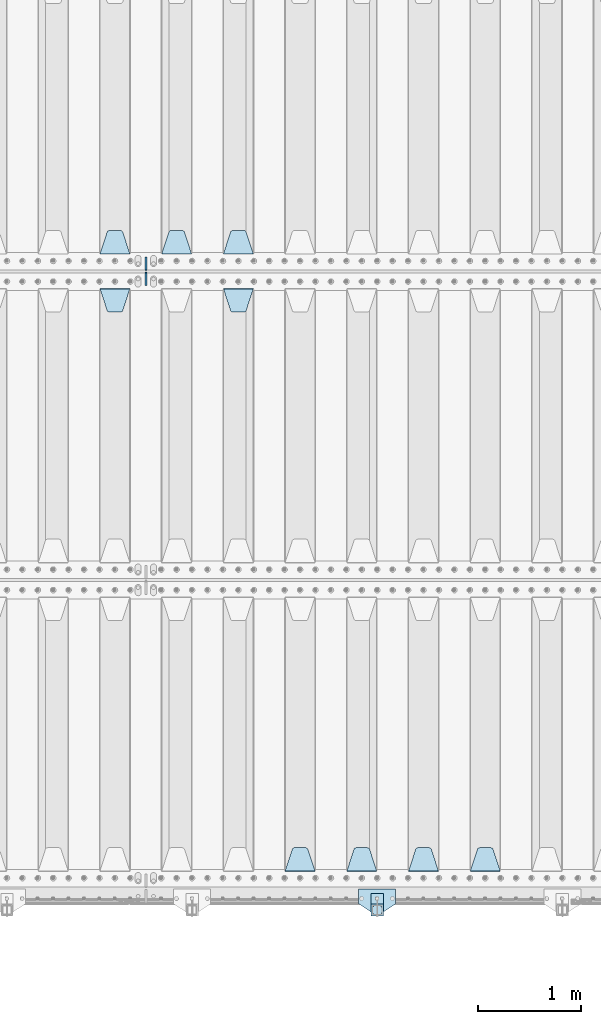
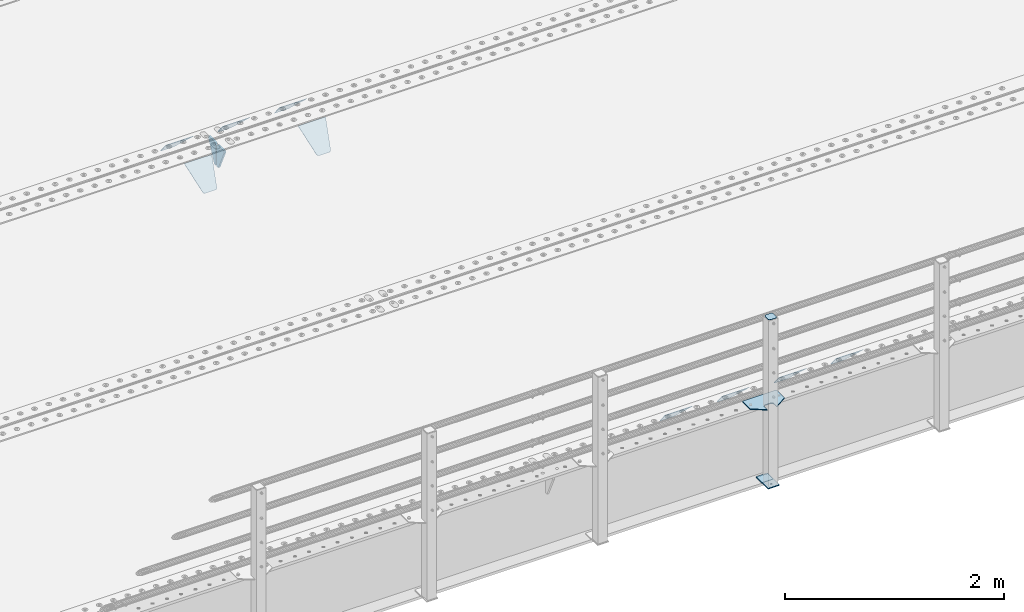
# One storey, part 208 of 257: 15 plates.
"""IFC2X3 building model written with IfcOpenShell, lengths in millimetres."""

from ifc_helpers import new_model, si_unit, frame, origin_with_axes, place, context, subcontext, project, spatial, faceted_brep, material, type_object, element, save


model = new_model("IFC2X3")

# Units and contexts
model_context = context("Model", 3, precision=1e-05, world=origin_with_axes())
body_context = subcontext(model_context, "Body", "Model", "MODEL_VIEW")
ifc_project = project(units=[si_unit("LENGTHUNIT", "METRE", prefix="MILLI"), si_unit("AREAUNIT", "SQUARE_METRE"), si_unit("VOLUMEUNIT", "CUBIC_METRE"), si_unit("MASSUNIT", "GRAM", prefix="KILO"), si_unit("TIMEUNIT", "SECOND"), si_unit("PLANEANGLEUNIT", "RADIAN"), si_unit("SOLIDANGLEUNIT", "STERADIAN"), si_unit("THERMODYNAMICTEMPERATUREUNIT", "DEGREE_CELSIUS"), si_unit("LUMINOUSINTENSITYUNIT", "LUMEN")], contexts=[model_context])

# Site, building, storey
site_placement = place(None, origin_with_axes())
site = spatial("IfcSite", under=ifc_project, at=site_placement, CompositionType="ELEMENT")
building_placement = place(site_placement, origin_with_axes())
building = spatial("IfcBuilding", under=site, at=building_placement, Name="Standard", CompositionType="ELEMENT")
storey_placement = place(building_placement, origin_with_axes())
storey = spatial("IfcBuildingStorey", under=building, at=storey_placement, Name="Undefined", CompositionType="ELEMENT", Elevation=0.0)

# Plates
ifc_material_1 = material(Name="STEEL/S355N")
plate_type_1 = type_object("IfcPlateType", PredefinedType="NOTDEFINED")
plate_1_placement = place(storey_placement, frame((51395.0, 168.232233047034, -1.76776695296758), z_axis=(0.0, 0.707106781186547, -0.707106781186548), x_axis=(-1.0, 0.0, 0.0)))
element("IfcPlate", 1, at=plate_1_placement, inside=storey, type_object=plate_type_1, material=ifc_material_1, context=body_context, shape_type="Brep", body=[
    faceted_brep([(0.0, -2.5, 0.0), (69.345504679477, -2.50000000000091, 300.17173142483), (69.345504679477, 2.5, 300.171731424831), (0.0, 2.5, 0.0), (70.927406119954, -2.50000000000091, 304.8974424154), (70.927406119954, 2.5, 304.8974424154), (73.3818627772271, -2.50000000000091, 309.234538108527), (73.3818627772271, 2.49999999999909, 309.234538108527), (76.6187032999587, -2.5, 313.023683126103), (76.6187032999587, 2.5, 313.023683126103), (80.5190132705029, -2.5, 316.125672595372), (80.5190132705029, 2.5, 316.125672595371), (84.9395038596849, -2.5, 318.426546230476), (84.9395038596849, 2.5, 318.426546230477), (89.7177759439219, -2.5, 319.841774983275), (89.7177759439219, 2.5, 319.841774983275), (94.6782862926484, -2.5, 320.319366455079), (94.6782862926484, 2.5, 320.319366455079), (195.321713707352, -2.5, 320.319366455079), (195.321713707352, 2.5, 320.319366455079), (200.282224056078, -2.5, 319.841774983275), (200.282224056078, 2.49999999999909, 319.841774983275), (205.060496140315, -2.5, 318.426546230476), (205.060496140315, 2.49999999999909, 318.426546230475), (209.480986729497, -2.5, 316.125672595371), (209.480986729497, 2.5, 316.125672595371), (213.381296700041, -2.50000000000091, 313.023683126102), (213.381296700041, 2.5, 313.023683126103), (216.618137222766, -2.50000000000091, 309.234538108527), (216.618137222766, 2.5, 309.234538108527), (219.072593880039, -2.5, 304.897442415399), (219.072593880039, 2.5, 304.897442415399), (220.654495320523, -2.50000000000091, 300.17173142483), (220.654495320523, 2.5, 300.171731424831), (290.0, -2.50000000000091, 0.0), (290.0, 2.5, 9.09494701772928e-13)], [[[0, 1, 2, 3]], [[1, 4, 5, 2]], [[4, 6, 7, 5]], [[6, 8, 9, 7]], [[8, 10, 11, 9]], [[10, 12, 13, 11]], [[12, 14, 15, 13]], [[14, 16, 17, 15]], [[16, 18, 19, 17]], [[18, 20, 21, 19]], [[20, 22, 23, 21]], [[22, 24, 25, 23]], [[24, 26, 27, 25]], [[26, 28, 29, 27]], [[28, 30, 31, 29]], [[30, 32, 33, 31]], [[32, 34, 35, 33]], [[34, 0, 3, 35]], [[5, 7, 9, 11, 13, 15, 17, 19, 21, 23, 25, 27, 29, 31, 33, 35, 3, 2]], [[34, 32, 30, 28, 26, 24, 22, 20, 18, 16, 14, 12, 10, 8, 6, 4, 1, 0]]]),
])
plate_2_placement = place(storey_placement, frame((50795.0, 168.232233047034, -1.76776695296758), z_axis=(0.0, 0.707106781186547, -0.707106781186548), x_axis=(-1.0, 0.0, 0.0)))
element("IfcPlate", 2, at=plate_2_placement, inside=storey, type_object=plate_type_1, material=ifc_material_1, context=body_context, shape_type="Brep", body=[
    faceted_brep([(0.0, -2.5, 0.0), (69.345504679477, -2.50000000000091, 300.17173142483), (69.345504679477, 2.5, 300.171731424831), (0.0, 2.5, 0.0), (70.927406119954, -2.50000000000091, 304.8974424154), (70.927406119954, 2.5, 304.8974424154), (73.3818627772271, -2.50000000000091, 309.234538108527), (73.3818627772271, 2.49999999999909, 309.234538108527), (76.6187032999587, -2.5, 313.023683126103), (76.6187032999587, 2.5, 313.023683126103), (80.5190132705029, -2.5, 316.125672595372), (80.5190132705029, 2.5, 316.125672595371), (84.9395038596849, -2.5, 318.426546230476), (84.9395038596849, 2.5, 318.426546230477), (89.7177759439219, -2.5, 319.841774983275), (89.7177759439219, 2.5, 319.841774983275), (94.6782862926484, -2.5, 320.319366455079), (94.6782862926484, 2.5, 320.319366455079), (195.321713707352, -2.5, 320.319366455079), (195.321713707352, 2.5, 320.319366455079), (200.282224056078, -2.5, 319.841774983275), (200.282224056078, 2.49999999999909, 319.841774983275), (205.060496140315, -2.5, 318.426546230476), (205.060496140315, 2.49999999999909, 318.426546230475), (209.480986729497, -2.5, 316.125672595371), (209.480986729497, 2.5, 316.125672595371), (213.381296700041, -2.50000000000091, 313.023683126102), (213.381296700041, 2.5, 313.023683126103), (216.618137222766, -2.50000000000091, 309.234538108527), (216.618137222766, 2.5, 309.234538108527), (219.072593880039, -2.5, 304.897442415399), (219.072593880039, 2.5, 304.897442415399), (220.654495320523, -2.50000000000091, 300.17173142483), (220.654495320523, 2.5, 300.171731424831), (290.0, -2.50000000000091, 0.0), (290.0, 2.5, 9.09494701772928e-13)], [[[0, 1, 2, 3]], [[1, 4, 5, 2]], [[4, 6, 7, 5]], [[6, 8, 9, 7]], [[8, 10, 11, 9]], [[10, 12, 13, 11]], [[12, 14, 15, 13]], [[14, 16, 17, 15]], [[16, 18, 19, 17]], [[18, 20, 21, 19]], [[20, 22, 23, 21]], [[22, 24, 25, 23]], [[24, 26, 27, 25]], [[26, 28, 29, 27]], [[28, 30, 31, 29]], [[30, 32, 33, 31]], [[32, 34, 35, 33]], [[34, 0, 3, 35]], [[5, 7, 9, 11, 13, 15, 17, 19, 21, 23, 25, 27, 29, 31, 33, 35, 3, 2]], [[34, 32, 30, 28, 26, 24, 22, 20, 18, 16, 14, 12, 10, 8, 6, 4, 1, 0]]]),
])
plate_3_placement = place(storey_placement, frame((50195.0, 168.232233047034, -1.76776695296758), z_axis=(0.0, 0.707106781186547, -0.707106781186548), x_axis=(-1.0, 0.0, 0.0)))
element("IfcPlate", 3, at=plate_3_placement, inside=storey, type_object=plate_type_1, material=ifc_material_1, context=body_context, shape_type="Brep", body=[
    faceted_brep([(0.0, -2.5, 0.0), (69.345504679477, -2.50000000000091, 300.17173142483), (69.345504679477, 2.5, 300.171731424831), (0.0, 2.5, 0.0), (70.927406119954, -2.50000000000091, 304.8974424154), (70.927406119954, 2.5, 304.8974424154), (73.3818627772271, -2.50000000000091, 309.234538108527), (73.3818627772271, 2.49999999999909, 309.234538108527), (76.6187032999587, -2.5, 313.023683126103), (76.6187032999587, 2.5, 313.023683126103), (80.5190132705029, -2.5, 316.125672595372), (80.5190132705029, 2.5, 316.125672595371), (84.9395038596849, -2.5, 318.426546230476), (84.9395038596849, 2.5, 318.426546230477), (89.7177759439219, -2.5, 319.841774983275), (89.7177759439219, 2.5, 319.841774983275), (94.6782862926484, -2.5, 320.319366455079), (94.6782862926484, 2.5, 320.319366455079), (195.321713707352, -2.5, 320.319366455079), (195.321713707352, 2.5, 320.319366455079), (200.282224056078, -2.5, 319.841774983275), (200.282224056078, 2.49999999999909, 319.841774983275), (205.060496140315, -2.5, 318.426546230476), (205.060496140315, 2.49999999999909, 318.426546230475), (209.480986729497, -2.5, 316.125672595371), (209.480986729497, 2.5, 316.125672595371), (213.381296700041, -2.50000000000091, 313.023683126102), (213.381296700041, 2.5, 313.023683126103), (216.618137222766, -2.50000000000091, 309.234538108527), (216.618137222766, 2.5, 309.234538108527), (219.072593880039, -2.5, 304.897442415399), (219.072593880039, 2.5, 304.897442415399), (220.654495320523, -2.50000000000091, 300.17173142483), (220.654495320523, 2.5, 300.171731424831), (290.0, -2.50000000000091, 0.0), (290.0, 2.5, 9.09494701772928e-13)], [[[0, 1, 2, 3]], [[1, 4, 5, 2]], [[4, 6, 7, 5]], [[6, 8, 9, 7]], [[8, 10, 11, 9]], [[10, 12, 13, 11]], [[12, 14, 15, 13]], [[14, 16, 17, 15]], [[16, 18, 19, 17]], [[18, 20, 21, 19]], [[20, 22, 23, 21]], [[22, 24, 25, 23]], [[24, 26, 27, 25]], [[26, 28, 29, 27]], [[28, 30, 31, 29]], [[30, 32, 33, 31]], [[32, 34, 35, 33]], [[34, 0, 3, 35]], [[5, 7, 9, 11, 13, 15, 17, 19, 21, 23, 25, 27, 29, 31, 33, 35, 3, 2]], [[34, 32, 30, 28, 26, 24, 22, 20, 18, 16, 14, 12, 10, 8, 6, 4, 1, 0]]]),
])
plate_4_placement = place(storey_placement, frame((49595.0, 168.232233047034, -1.76776695296758), z_axis=(0.0, 0.707106781186547, -0.707106781186548), x_axis=(-1.0, 0.0, 0.0)))
element("IfcPlate", 4, at=plate_4_placement, inside=storey, type_object=plate_type_1, material=ifc_material_1, context=body_context, shape_type="Brep", body=[
    faceted_brep([(0.0, -2.5, 0.0), (69.345504679477, -2.50000000000091, 300.17173142483), (69.345504679477, 2.5, 300.171731424831), (0.0, 2.5, 0.0), (70.927406119954, -2.50000000000091, 304.8974424154), (70.927406119954, 2.5, 304.8974424154), (73.3818627772271, -2.50000000000091, 309.234538108527), (73.3818627772271, 2.49999999999909, 309.234538108527), (76.6187032999587, -2.5, 313.023683126103), (76.6187032999587, 2.5, 313.023683126103), (80.5190132705029, -2.5, 316.125672595372), (80.5190132705029, 2.5, 316.125672595371), (84.9395038596849, -2.5, 318.426546230476), (84.9395038596849, 2.5, 318.426546230477), (89.7177759439219, -2.5, 319.841774983275), (89.7177759439219, 2.5, 319.841774983275), (94.6782862926484, -2.5, 320.319366455079), (94.6782862926484, 2.5, 320.319366455079), (195.321713707352, -2.5, 320.319366455079), (195.321713707352, 2.5, 320.319366455079), (200.282224056078, -2.5, 319.841774983275), (200.282224056078, 2.49999999999909, 319.841774983275), (205.060496140315, -2.5, 318.426546230476), (205.060496140315, 2.49999999999909, 318.426546230475), (209.480986729497, -2.5, 316.125672595371), (209.480986729497, 2.5, 316.125672595371), (213.381296700041, -2.50000000000091, 313.023683126102), (213.381296700041, 2.5, 313.023683126103), (216.618137222766, -2.50000000000091, 309.234538108527), (216.618137222766, 2.5, 309.234538108527), (219.072593880039, -2.5, 304.897442415399), (219.072593880039, 2.5, 304.897442415399), (220.654495320523, -2.50000000000091, 300.17173142483), (220.654495320523, 2.5, 300.171731424831), (290.0, -2.50000000000091, 0.0), (290.0, 2.5, 9.09494701772928e-13)], [[[0, 1, 2, 3]], [[1, 4, 5, 2]], [[4, 6, 7, 5]], [[6, 8, 9, 7]], [[8, 10, 11, 9]], [[10, 12, 13, 11]], [[12, 14, 15, 13]], [[14, 16, 17, 15]], [[16, 18, 19, 17]], [[18, 20, 21, 19]], [[20, 22, 23, 21]], [[22, 24, 25, 23]], [[24, 26, 27, 25]], [[26, 28, 29, 27]], [[28, 30, 31, 29]], [[30, 32, 33, 31]], [[32, 34, 35, 33]], [[34, 0, 3, 35]], [[5, 7, 9, 11, 13, 15, 17, 19, 21, 23, 25, 27, 29, 31, 33, 35, 3, 2]], [[34, 32, 30, 28, 26, 24, 22, 20, 18, 16, 14, 12, 10, 8, 6, 4, 1, 0]]]),
])
plate_5_placement = place(storey_placement, frame((48995.0, 6168.23223304703, -1.76776695296758), z_axis=(0.0, 0.707106781186547, -0.707106781186548), x_axis=(-1.0, 0.0, 0.0)))
element("IfcPlate", 5, at=plate_5_placement, inside=storey, type_object=plate_type_1, material=ifc_material_1, context=body_context, shape_type="Brep", body=[
    faceted_brep([(0.0, -2.5, 0.0), (69.345504679477, -2.50000000000091, 300.17173142483), (69.345504679477, 2.5, 300.171731424831), (0.0, 2.5, 0.0), (70.927406119954, -2.50000000000091, 304.8974424154), (70.927406119954, 2.5, 304.8974424154), (73.3818627772271, -2.50000000000091, 309.234538108527), (73.3818627772271, 2.49999999999909, 309.234538108527), (76.6187032999587, -2.5, 313.023683126103), (76.6187032999587, 2.5, 313.023683126103), (80.5190132705029, -2.5, 316.125672595372), (80.5190132705029, 2.5, 316.125672595371), (84.9395038596849, -2.5, 318.426546230476), (84.9395038596849, 2.5, 318.426546230477), (89.7177759439219, -2.5, 319.841774983275), (89.7177759439219, 2.5, 319.841774983275), (94.6782862926484, -2.5, 320.319366455079), (94.6782862926484, 2.5, 320.319366455079), (195.321713707352, -2.5, 320.319366455079), (195.321713707352, 2.5, 320.319366455079), (200.282224056078, -2.5, 319.841774983275), (200.282224056078, 2.49999999999909, 319.841774983275), (205.060496140315, -2.5, 318.426546230476), (205.060496140315, 2.49999999999909, 318.426546230475), (209.480986729497, -2.5, 316.125672595371), (209.480986729497, 2.5, 316.125672595371), (213.381296700041, -2.50000000000091, 313.023683126102), (213.381296700041, 2.5, 313.023683126103), (216.618137222766, -2.50000000000091, 309.234538108527), (216.618137222766, 2.5, 309.234538108527), (219.072593880039, -2.5, 304.897442415399), (219.072593880039, 2.5, 304.897442415399), (220.654495320523, -2.50000000000091, 300.17173142483), (220.654495320523, 2.5, 300.171731424831), (290.0, -2.50000000000091, 0.0), (290.0, 2.5, 9.09494701772928e-13)], [[[0, 1, 2, 3]], [[1, 4, 5, 2]], [[4, 6, 7, 5]], [[6, 8, 9, 7]], [[8, 10, 11, 9]], [[10, 12, 13, 11]], [[12, 14, 15, 13]], [[14, 16, 17, 15]], [[16, 18, 19, 17]], [[18, 20, 21, 19]], [[20, 22, 23, 21]], [[22, 24, 25, 23]], [[24, 26, 27, 25]], [[26, 28, 29, 27]], [[28, 30, 31, 29]], [[30, 32, 33, 31]], [[32, 34, 35, 33]], [[34, 0, 3, 35]], [[5, 7, 9, 11, 13, 15, 17, 19, 21, 23, 25, 27, 29, 31, 33, 35, 3, 2]], [[34, 32, 30, 28, 26, 24, 22, 20, 18, 16, 14, 12, 10, 8, 6, 4, 1, 0]]]),
])
plate_6_placement = place(storey_placement, frame((48395.0, 6168.23223304703, -1.76776695296758), z_axis=(0.0, 0.707106781186547, -0.707106781186548), x_axis=(-1.0, 0.0, 0.0)))
element("IfcPlate", 6, at=plate_6_placement, inside=storey, type_object=plate_type_1, material=ifc_material_1, context=body_context, shape_type="Brep", body=[
    faceted_brep([(0.0, -2.5, 0.0), (69.345504679477, -2.50000000000091, 300.17173142483), (69.345504679477, 2.5, 300.171731424831), (0.0, 2.5, 0.0), (70.927406119954, -2.50000000000091, 304.8974424154), (70.927406119954, 2.5, 304.8974424154), (73.3818627772271, -2.50000000000091, 309.234538108527), (73.3818627772271, 2.49999999999909, 309.234538108527), (76.6187032999587, -2.5, 313.023683126103), (76.6187032999587, 2.5, 313.023683126103), (80.5190132705029, -2.5, 316.125672595372), (80.5190132705029, 2.5, 316.125672595371), (84.9395038596849, -2.5, 318.426546230476), (84.9395038596849, 2.5, 318.426546230477), (89.7177759439219, -2.5, 319.841774983275), (89.7177759439219, 2.5, 319.841774983275), (94.6782862926484, -2.5, 320.319366455079), (94.6782862926484, 2.5, 320.319366455079), (195.321713707352, -2.5, 320.319366455079), (195.321713707352, 2.5, 320.319366455079), (200.282224056078, -2.5, 319.841774983275), (200.282224056078, 2.49999999999909, 319.841774983275), (205.060496140315, -2.5, 318.426546230476), (205.060496140315, 2.49999999999909, 318.426546230475), (209.480986729497, -2.5, 316.125672595371), (209.480986729497, 2.5, 316.125672595371), (213.381296700041, -2.50000000000091, 313.023683126102), (213.381296700041, 2.5, 313.023683126103), (216.618137222766, -2.50000000000091, 309.234538108527), (216.618137222766, 2.5, 309.234538108527), (219.072593880039, -2.5, 304.897442415399), (219.072593880039, 2.5, 304.897442415399), (220.654495320523, -2.50000000000091, 300.17173142483), (220.654495320523, 2.5, 300.171731424831), (290.0, -2.50000000000091, 0.0), (290.0, 2.5, 9.09494701772928e-13)], [[[0, 1, 2, 3]], [[1, 4, 5, 2]], [[4, 6, 7, 5]], [[6, 8, 9, 7]], [[8, 10, 11, 9]], [[10, 12, 13, 11]], [[12, 14, 15, 13]], [[14, 16, 17, 15]], [[16, 18, 19, 17]], [[18, 20, 21, 19]], [[20, 22, 23, 21]], [[22, 24, 25, 23]], [[24, 26, 27, 25]], [[26, 28, 29, 27]], [[28, 30, 31, 29]], [[30, 32, 33, 31]], [[32, 34, 35, 33]], [[34, 0, 3, 35]], [[5, 7, 9, 11, 13, 15, 17, 19, 21, 23, 25, 27, 29, 31, 33, 35, 3, 2]], [[34, 32, 30, 28, 26, 24, 22, 20, 18, 16, 14, 12, 10, 8, 6, 4, 1, 0]]]),
])
plate_7_placement = place(storey_placement, frame((47795.0, 6168.23223304703, -1.76776695296758), z_axis=(0.0, 0.707106781186547, -0.707106781186548), x_axis=(-1.0, 0.0, 0.0)))
element("IfcPlate", 7, at=plate_7_placement, inside=storey, type_object=plate_type_1, material=ifc_material_1, context=body_context, shape_type="Brep", body=[
    faceted_brep([(0.0, -2.5, 0.0), (69.345504679477, -2.50000000000091, 300.17173142483), (69.345504679477, 2.5, 300.171731424831), (0.0, 2.5, 0.0), (70.927406119954, -2.50000000000091, 304.8974424154), (70.927406119954, 2.5, 304.8974424154), (73.3818627772271, -2.50000000000091, 309.234538108527), (73.3818627772271, 2.49999999999909, 309.234538108527), (76.6187032999587, -2.5, 313.023683126103), (76.6187032999587, 2.5, 313.023683126103), (80.5190132705029, -2.5, 316.125672595372), (80.5190132705029, 2.5, 316.125672595371), (84.9395038596849, -2.5, 318.426546230476), (84.9395038596849, 2.5, 318.426546230477), (89.7177759439219, -2.5, 319.841774983275), (89.7177759439219, 2.5, 319.841774983275), (94.6782862926484, -2.5, 320.319366455079), (94.6782862926484, 2.5, 320.319366455079), (195.321713707352, -2.5, 320.319366455079), (195.321713707352, 2.5, 320.319366455079), (200.282224056078, -2.5, 319.841774983275), (200.282224056078, 2.49999999999909, 319.841774983275), (205.060496140315, -2.5, 318.426546230476), (205.060496140315, 2.49999999999909, 318.426546230475), (209.480986729497, -2.5, 316.125672595371), (209.480986729497, 2.5, 316.125672595371), (213.381296700041, -2.50000000000091, 313.023683126102), (213.381296700041, 2.5, 313.023683126103), (216.618137222766, -2.50000000000091, 309.234538108527), (216.618137222766, 2.5, 309.234538108527), (219.072593880039, -2.5, 304.897442415399), (219.072593880039, 2.5, 304.897442415399), (220.654495320523, -2.50000000000091, 300.17173142483), (220.654495320523, 2.5, 300.171731424831), (290.0, -2.50000000000091, 0.0), (290.0, 2.5, 9.09494701772928e-13)], [[[0, 1, 2, 3]], [[1, 4, 5, 2]], [[4, 6, 7, 5]], [[6, 8, 9, 7]], [[8, 10, 11, 9]], [[10, 12, 13, 11]], [[12, 14, 15, 13]], [[14, 16, 17, 15]], [[16, 18, 19, 17]], [[18, 20, 21, 19]], [[20, 22, 23, 21]], [[22, 24, 25, 23]], [[24, 26, 27, 25]], [[26, 28, 29, 27]], [[28, 30, 31, 29]], [[30, 32, 33, 31]], [[32, 34, 35, 33]], [[34, 0, 3, 35]], [[5, 7, 9, 11, 13, 15, 17, 19, 21, 23, 25, 27, 29, 31, 33, 35, 3, 2]], [[34, 32, 30, 28, 26, 24, 22, 20, 18, 16, 14, 12, 10, 8, 6, 4, 1, 0]]]),
])
plate_8_placement = place(storey_placement, frame((48705.0, 5831.76776695594, -1.767766952965), z_axis=(0.0, -0.707106781186548, -0.707106781186547), x_axis=(1.0, 0.0, 0.0)))
element("IfcPlate", 8, at=plate_8_placement, inside=storey, type_object=plate_type_1, material=ifc_material_1, context=body_context, shape_type="Brep", body=[
    faceted_brep([(0.0, -2.5, 0.0), (69.345504679477, -2.50000000000091, 300.17173142483), (69.345504679477, 2.5, 300.171731424831), (0.0, 2.5, 0.0), (70.927406119954, -2.50000000000091, 304.8974424154), (70.927406119954, 2.5, 304.8974424154), (73.3818627772271, -2.50000000000091, 309.234538108527), (73.3818627772271, 2.49999999999909, 309.234538108527), (76.6187032999587, -2.5, 313.023683126103), (76.6187032999587, 2.5, 313.023683126103), (80.5190132705029, -2.5, 316.125672595372), (80.5190132705029, 2.5, 316.125672595371), (84.9395038596849, -2.5, 318.426546230476), (84.9395038596849, 2.5, 318.426546230477), (89.7177759439219, -2.5, 319.841774983275), (89.7177759439219, 2.5, 319.841774983275), (94.6782862926484, -2.5, 320.319366455079), (94.6782862926484, 2.5, 320.319366455079), (195.321713707352, -2.5, 320.319366455079), (195.321713707352, 2.5, 320.319366455079), (200.282224056078, -2.5, 319.841774983275), (200.282224056078, 2.49999999999909, 319.841774983275), (205.060496140315, -2.5, 318.426546230476), (205.060496140315, 2.49999999999909, 318.426546230475), (209.480986729497, -2.5, 316.125672595371), (209.480986729497, 2.5, 316.125672595371), (213.381296700041, -2.50000000000091, 313.023683126102), (213.381296700041, 2.5, 313.023683126103), (216.618137222766, -2.50000000000091, 309.234538108527), (216.618137222766, 2.5, 309.234538108527), (219.072593880039, -2.5, 304.897442415399), (219.072593880039, 2.5, 304.897442415399), (220.654495320523, -2.50000000000091, 300.17173142483), (220.654495320523, 2.5, 300.171731424831), (290.0, -2.50000000000091, 0.0), (290.0, 2.5, 9.09494701772928e-13)], [[[0, 1, 2, 3]], [[1, 4, 5, 2]], [[4, 6, 7, 5]], [[6, 8, 9, 7]], [[8, 10, 11, 9]], [[10, 12, 13, 11]], [[12, 14, 15, 13]], [[14, 16, 17, 15]], [[16, 18, 19, 17]], [[18, 20, 21, 19]], [[20, 22, 23, 21]], [[22, 24, 25, 23]], [[24, 26, 27, 25]], [[26, 28, 29, 27]], [[28, 30, 31, 29]], [[30, 32, 33, 31]], [[32, 34, 35, 33]], [[34, 0, 3, 35]], [[5, 7, 9, 11, 13, 15, 17, 19, 21, 23, 25, 27, 29, 31, 33, 35, 3, 2]], [[34, 32, 30, 28, 26, 24, 22, 20, 18, 16, 14, 12, 10, 8, 6, 4, 1, 0]]]),
])
plate_9_placement = place(storey_placement, frame((47505.0, 5831.76776695594, -1.767766952965), z_axis=(0.0, -0.707106781186548, -0.707106781186547), x_axis=(1.0, 0.0, 0.0)))
element("IfcPlate", 9, at=plate_9_placement, inside=storey, type_object=plate_type_1, material=ifc_material_1, context=body_context, shape_type="Brep", body=[
    faceted_brep([(0.0, -2.5, 0.0), (69.345504679477, -2.50000000000091, 300.17173142483), (69.345504679477, 2.5, 300.171731424831), (0.0, 2.5, 0.0), (70.927406119954, -2.50000000000091, 304.8974424154), (70.927406119954, 2.5, 304.8974424154), (73.3818627772271, -2.50000000000091, 309.234538108527), (73.3818627772271, 2.49999999999909, 309.234538108527), (76.6187032999587, -2.5, 313.023683126103), (76.6187032999587, 2.5, 313.023683126103), (80.5190132705029, -2.5, 316.125672595372), (80.5190132705029, 2.5, 316.125672595371), (84.9395038596849, -2.5, 318.426546230476), (84.9395038596849, 2.5, 318.426546230477), (89.7177759439219, -2.5, 319.841774983275), (89.7177759439219, 2.5, 319.841774983275), (94.6782862926484, -2.5, 320.319366455079), (94.6782862926484, 2.5, 320.319366455079), (195.321713707352, -2.5, 320.319366455079), (195.321713707352, 2.5, 320.319366455079), (200.282224056078, -2.5, 319.841774983275), (200.282224056078, 2.49999999999909, 319.841774983275), (205.060496140315, -2.5, 318.426546230476), (205.060496140315, 2.49999999999909, 318.426546230475), (209.480986729497, -2.5, 316.125672595371), (209.480986729497, 2.5, 316.125672595371), (213.381296700041, -2.50000000000091, 313.023683126102), (213.381296700041, 2.5, 313.023683126103), (216.618137222766, -2.50000000000091, 309.234538108527), (216.618137222766, 2.5, 309.234538108527), (219.072593880039, -2.5, 304.897442415399), (219.072593880039, 2.5, 304.897442415399), (220.654495320523, -2.50000000000091, 300.17173142483), (220.654495320523, 2.5, 300.171731424831), (290.0, -2.50000000000091, 0.0), (290.0, 2.5, 9.09494701772928e-13)], [[[0, 1, 2, 3]], [[1, 4, 5, 2]], [[4, 6, 7, 5]], [[6, 8, 9, 7]], [[8, 10, 11, 9]], [[10, 12, 13, 11]], [[12, 14, 15, 13]], [[14, 16, 17, 15]], [[16, 18, 19, 17]], [[18, 20, 21, 19]], [[20, 22, 23, 21]], [[22, 24, 25, 23]], [[24, 26, 27, 25]], [[26, 28, 29, 27]], [[28, 30, 31, 29]], [[30, 32, 33, 31]], [[32, 34, 35, 33]], [[34, 0, 3, 35]], [[5, 7, 9, 11, 13, 15, 17, 19, 21, 23, 25, 27, 29, 31, 33, 35, 3, 2]], [[34, 32, 30, 28, 26, 24, 22, 20, 18, 16, 14, 12, 10, 8, 6, 4, 1, 0]]]),
])
plate_type_2 = type_object("IfcPlateType", PredefinedType="NOTDEFINED")
for number, where, z_axis, x_axis in (
    (10, (47950.0, 6140.0, -30.0), (0.0, 0.0, -1.0), (0.0, -1.0, 0.0)),
    (11, (47950.0, 5860.0, -30.0), (0.0, 0.0, -1.0), (0.0, 1.0, 0.0)),
):
    element("IfcPlate", number, at=place(storey_placement, frame(where, z_axis=z_axis, x_axis=x_axis)), inside=storey, type_object=plate_type_2, material=ifc_material_1, context=body_context, shape_type="Brep", body=[
        faceted_brep([(0.0, -10.0, 0.0), (0.0, -10.0, 30.0), (0.0, 10.0, 30.0), (0.0, 10.0, 0.0), (102.0, -10.0, 250.0), (102.0, 10.0, 250.0), (132.0, -10.0, 250.0), (132.0, 10.0, 250.0), (132.0, -10.0, 30.0), (132.0, 10.0, 30.0), (131.544232590366, -10.0, 24.790554669992), (131.544232590366, 10.0, 24.790554669992), (130.190778623577, -10.0, 19.7393957002299), (130.190778623577, 10.0, 19.7393957002299), (127.980762113533, -10.0, 15.0), (127.980762113533, 10.0, 15.0), (124.981333293569, -10.0, 10.7163717094038), (124.981333293569, 10.0, 10.7163717094038), (121.283628290596, -10.0, 7.01866670643062), (121.283628290596, 10.0, 7.01866670643062), (117.0, -10.0, 4.01923788646684), (117.0, 10.0, 4.01923788646684), (112.26060429977, -10.0, 1.80922137642278), (112.26060429977, 10.0, 1.80922137642278), (107.209445330008, -10.0, 0.455767409633722), (107.209445330008, 10.0, 0.455767409633722), (102.0, -10.0, 0.0), (102.0, 10.0, 0.0)], [[[0, 1, 2, 3]], [[1, 4, 5, 2]], [[4, 6, 7, 5]], [[6, 8, 9, 7]], [[8, 10, 11, 9]], [[10, 12, 13, 11]], [[12, 14, 15, 13]], [[14, 16, 17, 15]], [[16, 18, 19, 17]], [[18, 20, 21, 19]], [[20, 22, 23, 21]], [[22, 24, 25, 23]], [[24, 26, 27, 25]], [[26, 0, 3, 27]], [[5, 7, 9, 11, 13, 15, 17, 19, 21, 23, 25, 27, 3, 2]], [[26, 24, 22, 20, 18, 16, 14, 12, 10, 8, 6, 4, 1, 0]]]),
    ])
ifc_material_2 = material(Name="STEEL/S355J2")
plate_type_3 = type_object("IfcPlateType", PredefinedType="NOTDEFINED")
plate_10_placement = place(storey_placement, frame((50380.0, -4.99999999999636, 5.00000000004911), z_axis=(0.0, -1.0, 0.0), x_axis=(-1.0, 0.0, 0.0)))
element("IfcPlate", 12, at=plate_10_placement, inside=storey, type_object=plate_type_3, material=ifc_material_2, context=body_context, shape_type="Brep", body=[
    faceted_brep([(0.0, -5.0, 0.0), (2.31396552408114e-06, -5.0, 145.0), (2.31396552408114e-06, 5.0, 145.0), (0.0, 5.0, 0.0), (130.0, -5.0, 230.0), (130.0, 5.0, 230.0), (130.0, -5.0, 180.0), (130.0, 5.0, 180.0), (130.48036798992, -5.0, 175.122741949597), (130.48036798992, 5.0, 175.122741949597), (131.903011687216, -5.0, 170.432914190873), (131.903011687216, 5.0, 170.432914190873), (134.213259692435, -5.0, 166.11074417451), (134.213259692435, 5.0, 166.11074417451), (137.322330470335, -5.0, 162.322330470337), (137.322330470335, 5.0, 162.322330470337), (141.110744174512, -5.0, 159.213259692437), (141.110744174512, 5.0, 159.213259692437), (145.432914190875, -5.0, 156.903011687218), (145.432914190875, 5.0, 156.903011687218), (150.122741949599, -5.0, 155.48036798992), (150.122741949599, 5.0, 155.48036798992), (155.0, -5.0, 155.0), (155.0, 5.0, 155.0), (205.0, -5.0, 155.0), (205.0, 5.0, 155.0), (209.877258050401, -5.0, 155.48036798992), (209.877258050401, 5.0, 155.48036798992), (214.567085809125, -5.0, 156.903011687218), (214.567085809125, 5.0, 156.903011687218), (218.889255825488, -5.0, 159.213259692437), (218.889255825488, 5.0, 159.213259692437), (222.677669529665, -5.0, 162.322330470337), (222.677669529665, 5.0, 162.322330470337), (225.786740307565, -5.0, 166.11074417451), (225.786740307565, 5.0, 166.11074417451), (228.096988312784, -5.0, 170.432914190873), (228.096988312784, 5.0, 170.432914190873), (229.51963201008, -5.0, 175.122741949597), (229.51963201008, 5.0, 175.122741949597), (230.0, -5.0, 180.0), (230.0, 5.0, 180.0), (230.0, -5.0, 230.0), (230.0, 5.0, 230.0), (360.0, -5.0, 145.0), (360.0, 5.0, 145.0), (360.0, -5.0, -7.27595761418343e-12), (360.0, 5.0, -7.27595761418343e-12)], [[[0, 1, 2, 3]], [[1, 4, 5, 2]], [[4, 6, 7, 5]], [[6, 8, 9, 7]], [[8, 10, 11, 9]], [[10, 12, 13, 11]], [[12, 14, 15, 13]], [[14, 16, 17, 15]], [[16, 18, 19, 17]], [[18, 20, 21, 19]], [[20, 22, 23, 21]], [[22, 24, 25, 23]], [[24, 26, 27, 25]], [[26, 28, 29, 27]], [[28, 30, 31, 29]], [[30, 32, 33, 31]], [[32, 34, 35, 33]], [[34, 36, 37, 35]], [[36, 38, 39, 37]], [[38, 40, 41, 39]], [[40, 42, 43, 41]], [[42, 44, 45, 43]], [[44, 46, 47, 45]], [[46, 0, 3, 47]], [[5, 7, 9, 11, 13, 15, 17, 19, 21, 23, 25, 27, 29, 31, 33, 35, 37, 39, 41, 43, 45, 47, 3, 2]], [[46, 44, 42, 40, 38, 36, 34, 32, 30, 28, 26, 24, 22, 20, 18, 16, 14, 12, 10, 8, 6, 4, 1, 0]]]),
])
plate_type_4 = type_object("IfcPlateType", PredefinedType="NOTDEFINED")
plate_11_placement = place(storey_placement, frame((50259.9999999999, -50.0000000002074, -850.000000000002), z_axis=(0.0, -1.0, 0.0), x_axis=(-1.0, 0.0, 0.0)))
element("IfcPlate", 13, at=plate_11_placement, inside=storey, type_object=plate_type_4, material=ifc_material_2, context=body_context, shape_type="Brep", body=[
    faceted_brep([(53.6360389691836, -5.0, 176.363961030469), (53.6360389691836, 5.0, 176.363961030469), (59.9999999998618, 5.0, 178.999999999791), (59.9999999998618, -5.0, 178.999999999791), (66.3639610305399, 5.0, 176.363961030469), (66.3639610305399, -5.0, 176.363961030469), (68.9999999998618, 5.0, 169.999999999791), (68.9999999998618, -5.0, 169.999999999791), (66.3639610305399, 5.0, 163.636038969113), (66.3639610305399, -5.0, 163.636038969113), (59.9999999998618, 5.0, 160.999999999791), (59.9999999998618, -5.0, 160.999999999791), (53.6360389691836, 5.0, 163.636038969113), (53.6360389691836, -5.0, 163.636038969113), (50.9999999998618, 5.0, 169.999999999791), (50.9999999998618, -5.0, 169.999999999791), (120.0, -5.0, 0.0), (120.0, -5.0, 220.0), (0.0, -5.0, 220.0), (0.0, -5.0, 0.0), (0.0, 5.0, 0.0), (120.0, 5.0, 0.0), (120.0, 5.0, 220.0), (0.0, 5.0, 220.0)], [[[0, 1, 2, 3]], [[3, 2, 4, 5]], [[5, 4, 6, 7]], [[7, 6, 8, 9]], [[9, 8, 10, 11]], [[11, 10, 12, 13]], [[13, 12, 14, 15]], [[15, 14, 1, 0]], [[16, 17, 18, 19], [11, 13, 15, 0, 3, 5, 7, 9]], [[16, 19, 20, 21]], [[17, 16, 21, 22]], [[18, 17, 22, 23]], [[19, 18, 23, 20]], [[22, 21, 20, 23], [2, 1, 14, 12, 10, 8, 6, 4]]]),
])
plate_type_5 = type_object("IfcPlateType", PredefinedType="NOTDEFINED")
plate_12_placement = place(storey_placement, frame((50155.9999999999, -166.000000000207, 1012.50000000001), z_axis=(0.0, -1.0, 0.0), x_axis=(1.0, 0.0, 0.0)))
element("IfcPlate", 14, at=plate_12_placement, inside=storey, type_object=plate_type_5, material=ifc_material_2, context=body_context, shape_type="Brep", body=[
    faceted_brep([(0.0, -2.5, 19.0), (0.0, -2.5, 69.0), (0.0, 2.5, 69.0), (0.0, 2.5, 19.0), (0.476369668547704, -2.5, 73.2278977451697), (0.476369668547704, 2.5, 73.2278977451697), (1.88159150985302, -2.5, 77.2437910432327), (1.88159150985302, 2.5, 77.2437910432327), (4.14520183311106, -2.5, 80.8463062353167), (4.14520183311106, 2.5, 80.8463062353167), (7.15369376468152, -2.5, 83.8547981668926), (7.15369376468152, 2.5, 83.8547981668926), (10.7562089567655, -2.5, 86.1184084901452), (10.7562089567655, 2.5, 86.1184084901452), (14.7721022548285, -2.5, 87.5236303314541), (14.7721022548285, 2.5, 87.5236303314541), (19.0, -2.5, 88.0), (19.0, 2.5, 88.0), (69.0, -2.5, 88.0), (69.0, 2.5, 88.0), (73.2278977451715, -2.5, 87.5236303314541), (73.2278977451715, 2.5, 87.5236303314541), (77.2437910432345, -2.5, 86.1184084901452), (77.2437910432345, 2.5, 86.1184084901452), (80.8463062353185, -2.5, 83.8547981668926), (80.8463062353185, 2.5, 83.8547981668926), (83.8547981668889, -2.5, 80.8463062353167), (83.8547981668889, 2.5, 80.8463062353167), (86.118408490147, -2.5, 77.2437910432327), (86.118408490147, 2.5, 77.2437910432327), (87.5236303314523, -2.5, 73.2278977451697), (87.5236303314523, 2.5, 73.2278977451697), (88.0, -2.5, 69.0), (88.0, 2.5, 69.0), (88.0, -2.5, 19.0), (88.0, 2.5, 19.0), (87.5236303314523, -2.5, 14.7721022548303), (87.5236303314523, 2.5, 14.7721022548303), (86.118408490147, -2.5, 10.7562089567673), (86.118408490147, 2.5, 10.7562089567673), (83.8547981668889, -2.5, 7.15369376468334), (83.8547981668889, 2.5, 7.15369376468334), (80.8463062353185, -2.5, 4.14520183310742), (80.8463062353185, 2.5, 4.14520183310742), (77.2437910432345, -2.5, 1.88159150985484), (77.2437910432345, 2.5, 1.88159150985484), (73.2278977451715, -2.5, 0.476369668545885), (73.2278977451715, 2.5, 0.476369668545885), (69.0, -2.5, 0.0), (69.0, 2.5, 0.0), (19.0, -2.5, 0.0), (19.0, 2.5, 0.0), (14.7721022548285, -2.5, 0.476369668545885), (14.7721022548285, 2.5, 0.476369668545885), (10.7562089567655, -2.5, 1.88159150985484), (10.7562089567655, 2.5, 1.88159150985484), (7.15369376468152, -2.5, 4.14520183310742), (7.15369376468152, 2.5, 4.14520183310742), (4.14520183311106, -2.5, 7.15369376468334), (4.14520183311106, 2.5, 7.15369376468334), (1.88159150985302, -2.5, 10.7562089567673), (1.88159150985302, 2.5, 10.7562089567673), (0.476369668547704, -2.5, 14.7721022548303), (0.476369668547704, 2.5, 14.7721022548303)], [[[0, 1, 2, 3]], [[1, 4, 5, 2]], [[4, 6, 7, 5]], [[6, 8, 9, 7]], [[8, 10, 11, 9]], [[10, 12, 13, 11]], [[12, 14, 15, 13]], [[14, 16, 17, 15]], [[16, 18, 19, 17]], [[18, 20, 21, 19]], [[20, 22, 23, 21]], [[22, 24, 25, 23]], [[24, 26, 27, 25]], [[26, 28, 29, 27]], [[28, 30, 31, 29]], [[30, 32, 33, 31]], [[32, 34, 35, 33]], [[34, 36, 37, 35]], [[36, 38, 39, 37]], [[38, 40, 41, 39]], [[40, 42, 43, 41]], [[42, 44, 45, 43]], [[44, 46, 47, 45]], [[46, 48, 49, 47]], [[48, 50, 51, 49]], [[50, 52, 53, 51]], [[52, 54, 55, 53]], [[54, 56, 57, 55]], [[56, 58, 59, 57]], [[58, 60, 61, 59]], [[60, 62, 63, 61]], [[62, 0, 3, 63]], [[5, 7, 9, 11, 13, 15, 17, 19, 21, 23, 25, 27, 29, 31, 33, 35, 37, 39, 41, 43, 45, 47, 49, 51, 53, 55, 57, 59, 61, 63, 3, 2]], [[62, 60, 58, 56, 54, 52, 50, 48, 46, 44, 42, 40, 38, 36, 34, 32, 30, 28, 26, 24, 22, 20, 18, 16, 14, 12, 10, 8, 6, 4, 1, 0]]]),
])
plate_type_6 = type_object("IfcPlateType", PredefinedType="NOTDEFINED")
plate_13_placement = place(storey_placement, frame((50259.9999999999, -50.0000000002074, -857.500000000002), z_axis=(0.0, -1.0, 0.0), x_axis=(-1.0, 0.0, 0.0)))
element("IfcPlate", 15, at=plate_13_placement, inside=storey, type_object=plate_type_6, material=ifc_material_2, context=body_context, shape_type="Brep", body=[
    faceted_brep([(0.0, -2.5, 0.0), (0.0, -2.5, 100.0), (0.0, 2.5, 100.0), (0.0, 2.5, 0.0), (120.0, -2.5, 100.0), (120.0, 2.5, 100.0), (120.0, -2.5, 0.0), (120.0, 2.5, 0.0)], [[[0, 1, 2, 3]], [[1, 4, 5, 2]], [[4, 6, 7, 5]], [[6, 0, 3, 7]], [[5, 7, 3, 2]], [[6, 4, 1, 0]]]),
])

save(model, "model.ifc")
